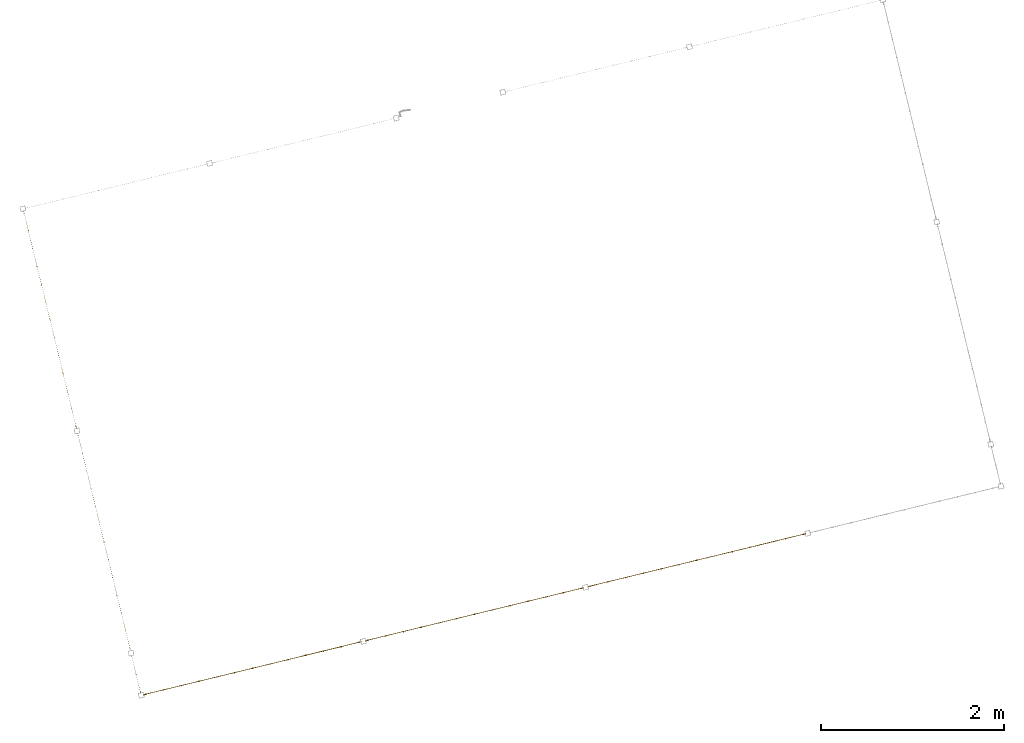
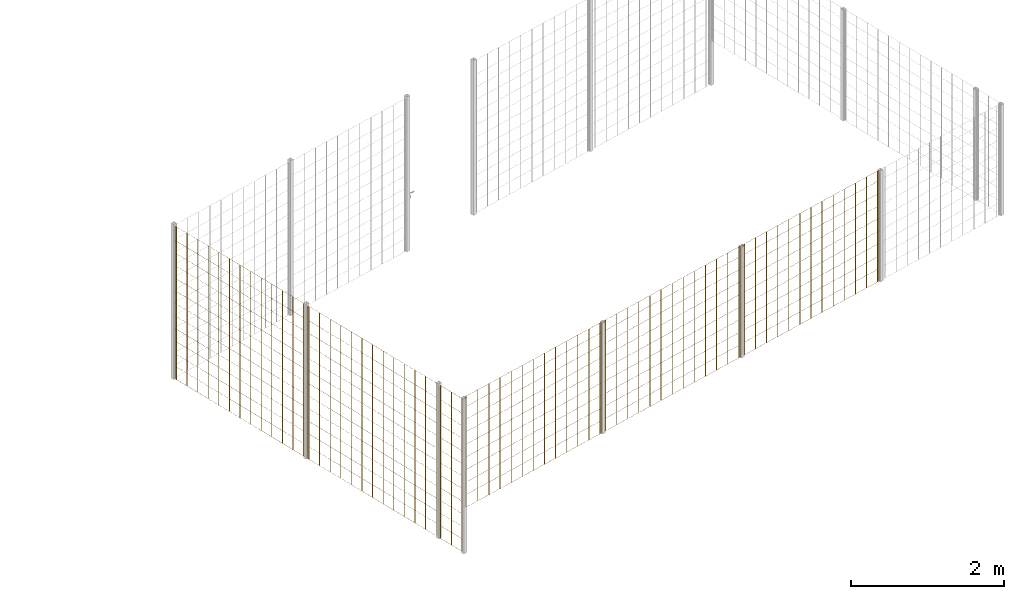
# One storey, part 7 of 10: 6 railings.
"""IFC2X3 building model written with IfcOpenShell, lengths in millimetres."""

from ifc_helpers import new_model, entity, si_unit, converted_unit, derived_unit, direction, frame, origin, origin_2d_with_axis, place, context, subcontext, project, spatial, rectangle, circle, extrude, material, material_list, element, save


model = new_model("IFC2X3")

# Units and contexts
model_context = context("Model", 3, precision=0.01, world=origin(), true_north=direction((6.12303176911189e-17, 1.0)))
body_context = subcontext(model_context, "Body", "Model", "MODEL_VIEW")
ifc_project = project(units=[si_unit("LENGTHUNIT", "METRE", prefix="MILLI"), si_unit("AREAUNIT", "SQUARE_METRE"), si_unit("VOLUMEUNIT", "CUBIC_METRE"), converted_unit("PLANEANGLEUNIT", "DEGREE", entity("IfcRatioMeasure", 0.0174532925199433), si_unit("PLANEANGLEUNIT", "RADIAN"), dimensions=[0, 0, 0, 0, 0, 0, 0]), si_unit("MASSUNIT", "GRAM", prefix="KILO"), derived_unit("MASSDENSITYUNIT", [(si_unit("MASSUNIT", "GRAM", prefix="KILO"), 1), (si_unit("LENGTHUNIT", "METRE"), -3)]), derived_unit("MOMENTOFINERTIAUNIT", [(si_unit("LENGTHUNIT", "METRE"), 4)]), si_unit("TIMEUNIT", "SECOND"), si_unit("FREQUENCYUNIT", "HERTZ"), si_unit("THERMODYNAMICTEMPERATUREUNIT", "DEGREE_CELSIUS"), derived_unit("THERMALTRANSMITTANCEUNIT", [(si_unit("MASSUNIT", "GRAM", prefix="KILO"), 1), (si_unit("THERMODYNAMICTEMPERATUREUNIT", "KELVIN"), -1), (si_unit("TIMEUNIT", "SECOND"), -3)]), derived_unit("VOLUMETRICFLOWRATEUNIT", [(si_unit("LENGTHUNIT", "METRE"), 3), (si_unit("TIMEUNIT", "SECOND"), -1)]), derived_unit("MASSFLOWRATEUNIT", [(si_unit("MASSUNIT", "GRAM", prefix="KILO"), 1), (si_unit("TIMEUNIT", "SECOND"), -1)]), derived_unit("ROTATIONALFREQUENCYUNIT", [(si_unit("TIMEUNIT", "SECOND"), -1)]), si_unit("ELECTRICCURRENTUNIT", "AMPERE"), si_unit("ELECTRICVOLTAGEUNIT", "VOLT"), si_unit("POWERUNIT", "WATT"), si_unit("FORCEUNIT", "NEWTON", prefix="KILO"), si_unit("ILLUMINANCEUNIT", "LUX"), si_unit("LUMINOUSFLUXUNIT", "LUMEN"), si_unit("LUMINOUSINTENSITYUNIT", "CANDELA"), derived_unit("USERDEFINED", [(si_unit("MASSUNIT", "GRAM", prefix="KILO"), -1), (si_unit("LENGTHUNIT", "METRE"), -2), (si_unit("TIMEUNIT", "SECOND"), 3), (si_unit("LUMINOUSFLUXUNIT", "LUMEN"), 1)]), derived_unit("LINEARVELOCITYUNIT", [(si_unit("LENGTHUNIT", "METRE"), 1), (si_unit("TIMEUNIT", "SECOND"), -1)]), si_unit("PRESSUREUNIT", "PASCAL"), derived_unit("USERDEFINED", [(si_unit("LENGTHUNIT", "METRE"), -2), (si_unit("MASSUNIT", "GRAM", prefix="KILO"), 1), (si_unit("TIMEUNIT", "SECOND"), -2)]), derived_unit("LINEARFORCEUNIT", [(si_unit("MASSUNIT", "GRAM", prefix="KILO"), 1), (si_unit("LENGTHUNIT", "METRE"), 1), (si_unit("TIMEUNIT", "SECOND"), -2), (si_unit("LENGTHUNIT", "METRE"), -1)]), derived_unit("PLANARFORCEUNIT", [(si_unit("MASSUNIT", "GRAM", prefix="KILO"), 1), (si_unit("LENGTHUNIT", "METRE"), 1), (si_unit("TIMEUNIT", "SECOND"), -2), (si_unit("LENGTHUNIT", "METRE"), -2)])], contexts=[model_context])

# Site, building, storey
site_placement = place(None, frame((19171.75, -72498.58, 0.0), z_axis=(0.0, 0.0, 1.0), x_axis=(0.971695960795463, 0.236234967296933, 0.0)))
site = spatial("IfcSite", under=ifc_project, at=site_placement, CompositionType="ELEMENT")
building_placement = place(site_placement, origin())
building = spatial("IfcBuilding", under=site, at=building_placement, CompositionType="ELEMENT")
storey_placement = place(building_placement, origin())
storey = spatial("IfcBuildingStorey", under=building, at=storey_placement, Name="01", CompositionType="ELEMENT", Elevation=0.0)

# Railings
ifc_material = material()
ifc_material_list_1 = material_list([ifc_material, ifc_material, ifc_material, ifc_material, ifc_material, ifc_material, ifc_material, ifc_material, ifc_material, ifc_material, ifc_material, ifc_material, ifc_material, ifc_material, ifc_material, ifc_material, ifc_material, ifc_material, ifc_material, ifc_material, ifc_material, ifc_material, ifc_material, ifc_material, ifc_material, ifc_material, ifc_material, ifc_material])
railing_1_placement = place(storey_placement, frame((193.41, 620.91, 0.0)))
element("IfcRailing", 1, at=railing_1_placement, inside=storey, material=ifc_material_list_1, PredefinedType="NOTDEFINED", context=body_context, shape_type="SweptSolid", body=[
    extrude(circle(Radius=5.0, at=origin_2d_with_axis()), frame((6.59, 2429.09, 2.0), z_axis=(0.0, 0.0, 1.0), x_axis=(-1.0, 0.0, 0.0)), (0.0, 0.0, 1.0), 2428.0),
    extrude(circle(Radius=5.0, at=origin_2d_with_axis()), frame((6.59, 2229.09, 2.0), z_axis=(0.0, 0.0, 1.0), x_axis=(-1.0, 0.0, 0.0)), (0.0, 0.0, 1.0), 2428.0),
    extrude(circle(Radius=5.0, at=origin_2d_with_axis()), frame((6.59, 2029.09, 2.0), z_axis=(0.0, 0.0, 1.0), x_axis=(-1.0, 0.0, 0.0)), (0.0, 0.0, 1.0), 2428.0),
    extrude(circle(Radius=5.0, at=origin_2d_with_axis()), frame((6.59, 1829.09, 2.0), z_axis=(0.0, 0.0, 1.0), x_axis=(-1.0, 0.0, 0.0)), (0.0, 0.0, 1.0), 2428.0),
    extrude(circle(Radius=5.0, at=origin_2d_with_axis()), frame((6.59, 1629.09, 2.0), z_axis=(0.0, 0.0, 1.0), x_axis=(-1.0, 0.0, 0.0)), (0.0, 0.0, 1.0), 2428.0),
    extrude(circle(Radius=5.0, at=origin_2d_with_axis()), frame((6.59, 1429.09, 2.0), z_axis=(0.0, 0.0, 1.0), x_axis=(-1.0, 0.0, 0.0)), (0.0, 0.0, 1.0), 2428.0),
    extrude(circle(Radius=5.0, at=origin_2d_with_axis()), frame((6.59, 1229.09, 2.0), z_axis=(0.0, 0.0, 1.0), x_axis=(-1.0, 0.0, 0.0)), (0.0, 0.0, 1.0), 2428.0),
    extrude(circle(Radius=5.0, at=origin_2d_with_axis()), frame((6.59, 1029.09, 2.0), z_axis=(0.0, 0.0, 1.0), x_axis=(-1.0, 0.0, 0.0)), (0.0, 0.0, 1.0), 2428.0),
    extrude(circle(Radius=5.0, at=origin_2d_with_axis()), frame((6.59, 829.09, 2.0), z_axis=(0.0, 0.0, 1.0), x_axis=(-1.0, 0.0, 0.0)), (0.0, 0.0, 1.0), 2428.0),
    extrude(circle(Radius=5.0, at=origin_2d_with_axis()), frame((6.59, 629.09, 2.0), z_axis=(0.0, 0.0, 1.0), x_axis=(-1.0, 0.0, 0.0)), (0.0, 0.0, 1.0), 2428.0),
    extrude(circle(Radius=5.0, at=origin_2d_with_axis()), frame((6.59, 429.09, 2.0), z_axis=(0.0, 0.0, 1.0), x_axis=(-1.0, 0.0, 0.0)), (0.0, 0.0, 1.0), 2428.0),
    extrude(circle(Radius=5.0, at=origin_2d_with_axis()), frame((6.59, 229.09, 2.0), z_axis=(0.0, 0.0, 1.0), x_axis=(-1.0, 0.0, 0.0)), (0.0, 0.0, 1.0), 2428.0),
    extrude(circle(Radius=5.0, at=origin_2d_with_axis()), frame((6.59, 29.09, 2.0), z_axis=(0.0, 0.0, 1.0), x_axis=(-1.0, 0.0, 0.0)), (0.0, 0.0, 1.0), 2428.0),
    extrude(circle(Radius=5.0, at=origin_2d_with_axis()), frame((6.59, 2451.59, 2.0), z_axis=(0.0, 0.0, 1.0), x_axis=(-1.0, 0.0, 0.0)), (0.0, 0.0, 1.0), 2428.0),
    extrude(circle(Radius=5.0, at=origin_2d_with_axis()), frame((6.59, 6.59, 2.0), z_axis=(0.0, 0.0, 1.0), x_axis=(-1.0, 0.0, 0.0)), (0.0, 0.0, 1.0), 2428.0),
    extrude(rectangle(XDim=2445.0, YDim=1.99999999999988, at=origin_2d_with_axis()), frame((7.59, 1229.09, 0.0), z_axis=(0.0, 0.0, 1.0), x_axis=(0.0, 1.0, 0.0)), (0.0, 0.0, 1.0), 2.00000000000043),
    extrude(rectangle(XDim=2445.0, YDim=1.99999999999988, at=origin_2d_with_axis()), frame((7.59, 1229.09, 200.0), z_axis=(0.0, 0.0, 1.0), x_axis=(0.0, 1.0, 0.0)), (0.0, 0.0, 1.0), 2.00000000000043),
    extrude(rectangle(XDim=2445.0, YDim=1.99999999999988, at=origin_2d_with_axis()), frame((7.59, 1229.09, 400.0), z_axis=(0.0, 0.0, 1.0), x_axis=(0.0, 1.0, 0.0)), (0.0, 0.0, 1.0), 2.00000000000043),
    extrude(rectangle(XDim=2445.0, YDim=1.99999999999988, at=origin_2d_with_axis()), frame((7.59, 1229.09, 600.0), z_axis=(0.0, 0.0, 1.0), x_axis=(0.0, 1.0, 0.0)), (0.0, 0.0, 1.0), 2.00000000000043),
    extrude(rectangle(XDim=2445.0, YDim=1.99999999999988, at=origin_2d_with_axis()), frame((7.59, 1229.09, 800.0), z_axis=(0.0, 0.0, 1.0), x_axis=(0.0, 1.0, 0.0)), (0.0, 0.0, 1.0), 2.00000000000036),
    extrude(rectangle(XDim=2445.0, YDim=1.99999999999988, at=origin_2d_with_axis()), frame((7.59, 1229.09, 1000.0), z_axis=(0.0, 0.0, 1.0), x_axis=(0.0, 1.0, 0.0)), (0.0, 0.0, 1.0), 2.00000000000036),
    extrude(rectangle(XDim=2445.0, YDim=1.99999999999988, at=origin_2d_with_axis()), frame((7.59, 1229.09, 1200.0), z_axis=(0.0, 0.0, 1.0), x_axis=(0.0, 1.0, 0.0)), (0.0, 0.0, 1.0), 2.00000000000036),
    extrude(rectangle(XDim=2445.0, YDim=1.99999999999988, at=origin_2d_with_axis()), frame((7.59, 1229.09, 1400.0), z_axis=(0.0, 0.0, 1.0), x_axis=(0.0, 1.0, 0.0)), (0.0, 0.0, 1.0), 2.00000000000036),
    extrude(rectangle(XDim=2445.0, YDim=1.99999999999988, at=origin_2d_with_axis()), frame((7.59, 1229.09, 1600.0), z_axis=(0.0, 0.0, 1.0), x_axis=(0.0, 1.0, 0.0)), (0.0, 0.0, 1.0), 2.00000000000036),
    extrude(rectangle(XDim=2445.0, YDim=1.99999999999988, at=origin_2d_with_axis()), frame((7.59, 1229.09, 1800.0), z_axis=(0.0, 0.0, 1.0), x_axis=(0.0, 1.0, 0.0)), (0.0, 0.0, 1.0), 2.00000000000036),
    extrude(rectangle(XDim=2445.0, YDim=1.99999999999988, at=origin_2d_with_axis()), frame((7.59, 1229.09, 2000.0), z_axis=(0.0, 0.0, 1.0), x_axis=(0.0, 1.0, 0.0)), (0.0, 0.0, 1.0), 2.00000000000036),
    extrude(rectangle(XDim=2445.0, YDim=1.99999999999988, at=origin_2d_with_axis()), frame((7.59, 1229.09, 2200.0), z_axis=(0.0, 0.0, 1.0), x_axis=(0.0, 1.0, 0.0)), (0.0, 0.0, 1.0), 2.00000000000036),
    extrude(rectangle(XDim=2445.0, YDim=1.99999999999988, at=origin_2d_with_axis()), frame((7.59, 1229.09, 2430.0), z_axis=(0.0, 0.0, 1.0), x_axis=(0.0, 1.0, 0.0)), (0.0, 0.0, 1.0), 2.00000000000036),
])
railing_2_placement = place(storey_placement, frame((193.41, 3120.91, 0.0)))
element("IfcRailing", 2, at=railing_2_placement, inside=storey, material=ifc_material_list_1, PredefinedType="NOTDEFINED", context=body_context, shape_type="SweptSolid", body=[
    extrude(circle(Radius=5.0, at=origin_2d_with_axis()), frame((6.59, 2429.79, 2.0), z_axis=(0.0, 0.0, 1.0), x_axis=(-1.0, 0.0, 0.0)), (0.0, 0.0, 1.0), 2428.0),
    extrude(circle(Radius=5.0, at=origin_2d_with_axis()), frame((6.59, 2229.79, 2.0), z_axis=(0.0, 0.0, 1.0), x_axis=(-1.0, 0.0, 0.0)), (0.0, 0.0, 1.0), 2428.0),
    extrude(circle(Radius=5.0, at=origin_2d_with_axis()), frame((6.59, 2029.79, 2.0), z_axis=(0.0, 0.0, 1.0), x_axis=(-1.0, 0.0, 0.0)), (0.0, 0.0, 1.0), 2428.0),
    extrude(circle(Radius=5.0, at=origin_2d_with_axis()), frame((6.59, 1829.79, 2.0), z_axis=(0.0, 0.0, 1.0), x_axis=(-1.0, 0.0, 0.0)), (0.0, 0.0, 1.0), 2428.0),
    extrude(circle(Radius=5.0, at=origin_2d_with_axis()), frame((6.59, 1629.79, 2.0), z_axis=(0.0, 0.0, 1.0), x_axis=(-1.0, 0.0, 0.0)), (0.0, 0.0, 1.0), 2428.0),
    extrude(circle(Radius=5.0, at=origin_2d_with_axis()), frame((6.59, 1429.79, 2.0), z_axis=(0.0, 0.0, 1.0), x_axis=(-1.0, 0.0, 0.0)), (0.0, 0.0, 1.0), 2428.0),
    extrude(circle(Radius=5.0, at=origin_2d_with_axis()), frame((6.59, 1229.79, 2.0), z_axis=(0.0, 0.0, 1.0), x_axis=(-1.0, 0.0, 0.0)), (0.0, 0.0, 1.0), 2428.0),
    extrude(circle(Radius=5.0, at=origin_2d_with_axis()), frame((6.59, 1029.79, 2.0), z_axis=(0.0, 0.0, 1.0), x_axis=(-1.0, 0.0, 0.0)), (0.0, 0.0, 1.0), 2428.0),
    extrude(circle(Radius=5.0, at=origin_2d_with_axis()), frame((6.59, 829.79, 2.0), z_axis=(0.0, 0.0, 1.0), x_axis=(-1.0, 0.0, 0.0)), (0.0, 0.0, 1.0), 2428.0),
    extrude(circle(Radius=5.0, at=origin_2d_with_axis()), frame((6.59, 629.79, 2.0), z_axis=(0.0, 0.0, 1.0), x_axis=(-1.0, 0.0, 0.0)), (0.0, 0.0, 1.0), 2428.0),
    extrude(circle(Radius=5.0, at=origin_2d_with_axis()), frame((6.59, 429.79, 2.0), z_axis=(0.0, 0.0, 1.0), x_axis=(-1.0, 0.0, 0.0)), (0.0, 0.0, 1.0), 2428.0),
    extrude(circle(Radius=5.0, at=origin_2d_with_axis()), frame((6.59, 229.79, 2.0), z_axis=(0.0, 0.0, 1.0), x_axis=(-1.0, 0.0, 0.0)), (0.0, 0.0, 1.0), 2428.0),
    extrude(circle(Radius=5.0, at=origin_2d_with_axis()), frame((6.59, 29.79, 2.0), z_axis=(0.0, 0.0, 1.0), x_axis=(-1.0, 0.0, 0.0)), (0.0, 0.0, 1.0), 2428.0),
    extrude(circle(Radius=5.0, at=origin_2d_with_axis()), frame((6.59, 2452.99, 2.0), z_axis=(0.0, 0.0, 1.0), x_axis=(-1.0, 0.0, 0.0)), (0.0, 0.0, 1.0), 2428.0),
    extrude(circle(Radius=5.0, at=origin_2d_with_axis()), frame((6.59, 6.59, 2.0), z_axis=(0.0, 0.0, 1.0), x_axis=(-1.0, 0.0, 0.0)), (0.0, 0.0, 1.0), 2428.0),
    extrude(rectangle(XDim=2446.40000000003, YDim=1.99999999999988, at=origin_2d_with_axis()), frame((7.59, 1229.79, 0.0), z_axis=(0.0, 0.0, 1.0), x_axis=(0.0, 1.0, 0.0)), (0.0, 0.0, 1.0), 2.00000000000043),
    extrude(rectangle(XDim=2446.40000000003, YDim=1.99999999999988, at=origin_2d_with_axis()), frame((7.59, 1229.79, 200.0), z_axis=(0.0, 0.0, 1.0), x_axis=(0.0, 1.0, 0.0)), (0.0, 0.0, 1.0), 2.00000000000043),
    extrude(rectangle(XDim=2446.40000000003, YDim=1.99999999999988, at=origin_2d_with_axis()), frame((7.59, 1229.79, 400.0), z_axis=(0.0, 0.0, 1.0), x_axis=(0.0, 1.0, 0.0)), (0.0, 0.0, 1.0), 2.00000000000043),
    extrude(rectangle(XDim=2446.40000000003, YDim=1.99999999999988, at=origin_2d_with_axis()), frame((7.59, 1229.79, 600.0), z_axis=(0.0, 0.0, 1.0), x_axis=(0.0, 1.0, 0.0)), (0.0, 0.0, 1.0), 2.00000000000043),
    extrude(rectangle(XDim=2446.40000000003, YDim=1.99999999999988, at=origin_2d_with_axis()), frame((7.59, 1229.79, 800.0), z_axis=(0.0, 0.0, 1.0), x_axis=(0.0, 1.0, 0.0)), (0.0, 0.0, 1.0), 2.00000000000036),
    extrude(rectangle(XDim=2446.40000000003, YDim=1.99999999999988, at=origin_2d_with_axis()), frame((7.59, 1229.79, 1000.0), z_axis=(0.0, 0.0, 1.0), x_axis=(0.0, 1.0, 0.0)), (0.0, 0.0, 1.0), 2.00000000000036),
    extrude(rectangle(XDim=2446.40000000003, YDim=1.99999999999988, at=origin_2d_with_axis()), frame((7.59, 1229.79, 1200.0), z_axis=(0.0, 0.0, 1.0), x_axis=(0.0, 1.0, 0.0)), (0.0, 0.0, 1.0), 2.00000000000036),
    extrude(rectangle(XDim=2446.40000000003, YDim=1.99999999999988, at=origin_2d_with_axis()), frame((7.59, 1229.79, 1400.0), z_axis=(0.0, 0.0, 1.0), x_axis=(0.0, 1.0, 0.0)), (0.0, 0.0, 1.0), 2.00000000000036),
    extrude(rectangle(XDim=2446.40000000003, YDim=1.99999999999988, at=origin_2d_with_axis()), frame((7.59, 1229.79, 1600.0), z_axis=(0.0, 0.0, 1.0), x_axis=(0.0, 1.0, 0.0)), (0.0, 0.0, 1.0), 2.00000000000036),
    extrude(rectangle(XDim=2446.40000000003, YDim=1.99999999999988, at=origin_2d_with_axis()), frame((7.59, 1229.79, 1800.0), z_axis=(0.0, 0.0, 1.0), x_axis=(0.0, 1.0, 0.0)), (0.0, 0.0, 1.0), 2.00000000000036),
    extrude(rectangle(XDim=2446.40000000003, YDim=1.99999999999988, at=origin_2d_with_axis()), frame((7.59, 1229.79, 2000.0), z_axis=(0.0, 0.0, 1.0), x_axis=(0.0, 1.0, 0.0)), (0.0, 0.0, 1.0), 2.00000000000036),
    extrude(rectangle(XDim=2446.40000000003, YDim=1.99999999999988, at=origin_2d_with_axis()), frame((7.59, 1229.79, 2200.0), z_axis=(0.0, 0.0, 1.0), x_axis=(0.0, 1.0, 0.0)), (0.0, 0.0, 1.0), 2.00000000000036),
    extrude(rectangle(XDim=2446.40000000003, YDim=1.99999999999988, at=origin_2d_with_axis()), frame((7.59, 1229.79, 2430.0), z_axis=(0.0, 0.0, 1.0), x_axis=(0.0, 1.0, 0.0)), (0.0, 0.0, 1.0), 2.00000000000036),
])
ifc_material_list_2 = material_list([ifc_material, ifc_material, ifc_material, ifc_material, ifc_material, ifc_material, ifc_material, ifc_material, ifc_material, ifc_material, ifc_material, ifc_material, ifc_material, ifc_material, ifc_material, ifc_material, ifc_material, ifc_material, ifc_material, ifc_material, ifc_material, ifc_material, ifc_material, ifc_material, ifc_material])
railing_3_placement = place(storey_placement, frame((5220.91, 118.41, 700.0)))
element("IfcRailing", 3, at=railing_3_placement, inside=storey, material=ifc_material_list_2, Name=": 2", ObjectType=": 2", PredefinedType="NOTDEFINED", context=body_context, shape_type="SweptSolid", body=[
    extrude(circle(Radius=5.0, at=origin_2d_with_axis()), frame((29.79, 6.59, 2.0), z_axis=(0.0, 0.0, 1.0), x_axis=(0.0, -1.0, 0.0)), (0.0, 0.0, 1.0), 1763.0),
    extrude(circle(Radius=5.0, at=origin_2d_with_axis()), frame((229.79, 6.59, 2.0), z_axis=(0.0, 0.0, 1.0), x_axis=(0.0, -1.0, 0.0)), (0.0, 0.0, 1.0), 1763.0),
    extrude(circle(Radius=5.0, at=origin_2d_with_axis()), frame((429.79, 6.59, 2.0), z_axis=(0.0, 0.0, 1.0), x_axis=(0.0, -1.0, 0.0)), (0.0, 0.0, 1.0), 1763.0),
    extrude(circle(Radius=5.0, at=origin_2d_with_axis()), frame((629.79, 6.59, 2.0), z_axis=(0.0, 0.0, 1.0), x_axis=(0.0, -1.0, 0.0)), (0.0, 0.0, 1.0), 1763.0),
    extrude(circle(Radius=5.0, at=origin_2d_with_axis()), frame((829.79, 6.59, 2.0), z_axis=(0.0, 0.0, 1.0), x_axis=(0.0, -1.0, 0.0)), (0.0, 0.0, 1.0), 1763.0),
    extrude(circle(Radius=5.0, at=origin_2d_with_axis()), frame((1029.79, 6.59, 2.0), z_axis=(0.0, 0.0, 1.0), x_axis=(0.0, -1.0, 0.0)), (0.0, 0.0, 1.0), 1763.0),
    extrude(circle(Radius=5.0, at=origin_2d_with_axis()), frame((1229.79, 6.59, 2.0), z_axis=(0.0, 0.0, 1.0), x_axis=(0.0, -1.0, 0.0)), (0.0, 0.0, 1.0), 1763.0),
    extrude(circle(Radius=5.0, at=origin_2d_with_axis()), frame((1429.79, 6.59, 2.0), z_axis=(0.0, 0.0, 1.0), x_axis=(0.0, -1.0, 0.0)), (0.0, 0.0, 1.0), 1763.0),
    extrude(circle(Radius=5.0, at=origin_2d_with_axis()), frame((1629.79, 6.59, 2.0), z_axis=(0.0, 0.0, 1.0), x_axis=(0.0, -1.0, 0.0)), (0.0, 0.0, 1.0), 1763.0),
    extrude(circle(Radius=5.0, at=origin_2d_with_axis()), frame((1829.79, 6.59, 2.0), z_axis=(0.0, 0.0, 1.0), x_axis=(0.0, -1.0, 0.0)), (0.0, 0.0, 1.0), 1763.0),
    extrude(circle(Radius=5.0, at=origin_2d_with_axis()), frame((2029.79, 6.59, 2.0), z_axis=(0.0, 0.0, 1.0), x_axis=(0.0, -1.0, 0.0)), (0.0, 0.0, 1.0), 1763.0),
    extrude(circle(Radius=5.0, at=origin_2d_with_axis()), frame((2229.79, 6.59, 2.0), z_axis=(0.0, 0.0, 1.0), x_axis=(0.0, -1.0, 0.0)), (0.0, 0.0, 1.0), 1763.0),
    extrude(circle(Radius=5.0, at=origin_2d_with_axis()), frame((2429.79, 6.59, 2.0), z_axis=(0.0, 0.0, 1.0), x_axis=(0.0, -1.0, 0.0)), (0.0, 0.0, 1.0), 1763.0),
    extrude(circle(Radius=5.0, at=origin_2d_with_axis()), frame((6.59, 6.59, 2.0), z_axis=(0.0, 0.0, 1.0), x_axis=(0.0, -1.0, 0.0)), (0.0, 0.0, 1.0), 1763.0),
    extrude(circle(Radius=5.0, at=origin_2d_with_axis()), frame((2452.99, 6.59, 2.0), z_axis=(0.0, 0.0, 1.0), x_axis=(0.0, -1.0, 0.0)), (0.0, 0.0, 1.0), 1763.0),
    extrude(rectangle(XDim=2446.4, YDim=1.99999999999988, at=origin_2d_with_axis()), frame((1229.79, 7.59, 0.0), z_axis=(0.0, 0.0, 1.0), x_axis=(-1.0, 0.0, 0.0)), (0.0, 0.0, 1.0), 2.00000000000036),
    extrude(rectangle(XDim=2446.4, YDim=1.99999999999988, at=origin_2d_with_axis()), frame((1229.79, 7.59, 200.0), z_axis=(0.0, 0.0, 1.0), x_axis=(-1.0, 0.0, 0.0)), (0.0, 0.0, 1.0), 2.00000000000036),
    extrude(rectangle(XDim=2446.4, YDim=1.99999999999988, at=origin_2d_with_axis()), frame((1229.79, 7.59, 400.0), z_axis=(0.0, 0.0, 1.0), x_axis=(-1.0, 0.0, 0.0)), (0.0, 0.0, 1.0), 2.00000000000036),
    extrude(rectangle(XDim=2446.4, YDim=1.99999999999988, at=origin_2d_with_axis()), frame((1229.79, 7.59, 600.0), z_axis=(0.0, 0.0, 1.0), x_axis=(-1.0, 0.0, 0.0)), (0.0, 0.0, 1.0), 2.00000000000036),
    extrude(rectangle(XDim=2446.4, YDim=1.99999999999988, at=origin_2d_with_axis()), frame((1229.79, 7.59, 800.0), z_axis=(0.0, 0.0, 1.0), x_axis=(-1.0, 0.0, 0.0)), (0.0, 0.0, 1.0), 2.00000000000036),
    extrude(rectangle(XDim=2446.4, YDim=1.99999999999988, at=origin_2d_with_axis()), frame((1229.79, 7.59, 1000.0), z_axis=(0.0, 0.0, 1.0), x_axis=(-1.0, 0.0, 0.0)), (0.0, 0.0, 1.0), 2.00000000000036),
    extrude(rectangle(XDim=2446.4, YDim=1.99999999999988, at=origin_2d_with_axis()), frame((1229.79, 7.59, 1200.0), z_axis=(0.0, 0.0, 1.0), x_axis=(-1.0, 0.0, 0.0)), (0.0, 0.0, 1.0), 2.00000000000036),
    extrude(rectangle(XDim=2446.4, YDim=1.99999999999988, at=origin_2d_with_axis()), frame((1229.79, 7.59, 1400.0), z_axis=(0.0, 0.0, 1.0), x_axis=(-1.0, 0.0, 0.0)), (0.0, 0.0, 1.0), 2.00000000000036),
    extrude(rectangle(XDim=2446.4, YDim=1.99999999999988, at=origin_2d_with_axis()), frame((1229.79, 7.59, 1600.0), z_axis=(0.0, 0.0, 1.0), x_axis=(-1.0, 0.0, 0.0)), (0.0, 0.0, 1.0), 2.00000000000036),
    extrude(rectangle(XDim=2446.4, YDim=1.99999999999988, at=origin_2d_with_axis()), frame((1229.79, 7.59, 1765.0), z_axis=(0.0, 0.0, 1.0), x_axis=(-1.0, 0.0, 0.0)), (0.0, 0.0, 1.0), 2.00000000000063),
])
railing_4_placement = place(storey_placement, frame((2720.91, 118.41, 700.0)))
element("IfcRailing", 4, at=railing_4_placement, inside=storey, material=ifc_material_list_2, Name=": 2", ObjectType=": 2", PredefinedType="NOTDEFINED", context=body_context, shape_type="SweptSolid", body=[
    extrude(circle(Radius=5.0, at=origin_2d_with_axis()), frame((29.09, 6.59, 2.0), z_axis=(0.0, 0.0, 1.0), x_axis=(0.0, -1.0, 0.0)), (0.0, 0.0, 1.0), 1763.0),
    extrude(circle(Radius=5.0, at=origin_2d_with_axis()), frame((229.09, 6.59, 2.0), z_axis=(0.0, 0.0, 1.0), x_axis=(0.0, -1.0, 0.0)), (0.0, 0.0, 1.0), 1763.0),
    extrude(circle(Radius=5.0, at=origin_2d_with_axis()), frame((429.09, 6.59, 2.0), z_axis=(0.0, 0.0, 1.0), x_axis=(0.0, -1.0, 0.0)), (0.0, 0.0, 1.0), 1763.0),
    extrude(circle(Radius=5.0, at=origin_2d_with_axis()), frame((629.09, 6.59, 2.0), z_axis=(0.0, 0.0, 1.0), x_axis=(0.0, -1.0, 0.0)), (0.0, 0.0, 1.0), 1763.0),
    extrude(circle(Radius=5.0, at=origin_2d_with_axis()), frame((829.09, 6.59, 2.0), z_axis=(0.0, 0.0, 1.0), x_axis=(0.0, -1.0, 0.0)), (0.0, 0.0, 1.0), 1763.0),
    extrude(circle(Radius=5.0, at=origin_2d_with_axis()), frame((1029.09, 6.59, 2.0), z_axis=(0.0, 0.0, 1.0), x_axis=(0.0, -1.0, 0.0)), (0.0, 0.0, 1.0), 1763.0),
    extrude(circle(Radius=5.0, at=origin_2d_with_axis()), frame((1229.09, 6.59, 2.0), z_axis=(0.0, 0.0, 1.0), x_axis=(0.0, -1.0, 0.0)), (0.0, 0.0, 1.0), 1763.0),
    extrude(circle(Radius=5.0, at=origin_2d_with_axis()), frame((1429.09, 6.59, 2.0), z_axis=(0.0, 0.0, 1.0), x_axis=(0.0, -1.0, 0.0)), (0.0, 0.0, 1.0), 1763.0),
    extrude(circle(Radius=5.0, at=origin_2d_with_axis()), frame((1629.09, 6.59, 2.0), z_axis=(0.0, 0.0, 1.0), x_axis=(0.0, -1.0, 0.0)), (0.0, 0.0, 1.0), 1763.0),
    extrude(circle(Radius=5.0, at=origin_2d_with_axis()), frame((1829.09, 6.59, 2.0), z_axis=(0.0, 0.0, 1.0), x_axis=(0.0, -1.0, 0.0)), (0.0, 0.0, 1.0), 1763.0),
    extrude(circle(Radius=5.0, at=origin_2d_with_axis()), frame((2029.09, 6.59, 2.0), z_axis=(0.0, 0.0, 1.0), x_axis=(0.0, -1.0, 0.0)), (0.0, 0.0, 1.0), 1763.0),
    extrude(circle(Radius=5.0, at=origin_2d_with_axis()), frame((2229.09, 6.59, 2.0), z_axis=(0.0, 0.0, 1.0), x_axis=(0.0, -1.0, 0.0)), (0.0, 0.0, 1.0), 1763.0),
    extrude(circle(Radius=5.0, at=origin_2d_with_axis()), frame((2429.09, 6.59, 2.0), z_axis=(0.0, 0.0, 1.0), x_axis=(0.0, -1.0, 0.0)), (0.0, 0.0, 1.0), 1763.0),
    extrude(circle(Radius=5.0, at=origin_2d_with_axis()), frame((6.59, 6.59, 2.0), z_axis=(0.0, 0.0, 1.0), x_axis=(0.0, -1.0, 0.0)), (0.0, 0.0, 1.0), 1763.0),
    extrude(circle(Radius=5.0, at=origin_2d_with_axis()), frame((2451.59, 6.59, 2.0), z_axis=(0.0, 0.0, 1.0), x_axis=(0.0, -1.0, 0.0)), (0.0, 0.0, 1.0), 1763.0),
    extrude(rectangle(XDim=2445.0, YDim=1.9999999999999, at=origin_2d_with_axis()), frame((1229.09, 7.59, 0.0), z_axis=(0.0, 0.0, 1.0), x_axis=(-1.0, 0.0, 0.0)), (0.0, 0.0, 1.0), 2.00000000000036),
    extrude(rectangle(XDim=2445.0, YDim=1.9999999999999, at=origin_2d_with_axis()), frame((1229.09, 7.59, 200.0), z_axis=(0.0, 0.0, 1.0), x_axis=(-1.0, 0.0, 0.0)), (0.0, 0.0, 1.0), 2.00000000000036),
    extrude(rectangle(XDim=2445.0, YDim=1.9999999999999, at=origin_2d_with_axis()), frame((1229.09, 7.59, 400.0), z_axis=(0.0, 0.0, 1.0), x_axis=(-1.0, 0.0, 0.0)), (0.0, 0.0, 1.0), 2.00000000000036),
    extrude(rectangle(XDim=2445.0, YDim=1.9999999999999, at=origin_2d_with_axis()), frame((1229.09, 7.59, 600.0), z_axis=(0.0, 0.0, 1.0), x_axis=(-1.0, 0.0, 0.0)), (0.0, 0.0, 1.0), 2.00000000000036),
    extrude(rectangle(XDim=2445.0, YDim=1.9999999999999, at=origin_2d_with_axis()), frame((1229.09, 7.59, 800.0), z_axis=(0.0, 0.0, 1.0), x_axis=(-1.0, 0.0, 0.0)), (0.0, 0.0, 1.0), 2.00000000000036),
    extrude(rectangle(XDim=2445.0, YDim=1.9999999999999, at=origin_2d_with_axis()), frame((1229.09, 7.59, 1000.0), z_axis=(0.0, 0.0, 1.0), x_axis=(-1.0, 0.0, 0.0)), (0.0, 0.0, 1.0), 2.00000000000036),
    extrude(rectangle(XDim=2445.0, YDim=1.9999999999999, at=origin_2d_with_axis()), frame((1229.09, 7.59, 1200.0), z_axis=(0.0, 0.0, 1.0), x_axis=(-1.0, 0.0, 0.0)), (0.0, 0.0, 1.0), 2.00000000000036),
    extrude(rectangle(XDim=2445.0, YDim=1.9999999999999, at=origin_2d_with_axis()), frame((1229.09, 7.59, 1400.0), z_axis=(0.0, 0.0, 1.0), x_axis=(-1.0, 0.0, 0.0)), (0.0, 0.0, 1.0), 2.00000000000036),
    extrude(rectangle(XDim=2445.0, YDim=1.9999999999999, at=origin_2d_with_axis()), frame((1229.09, 7.59, 1600.0), z_axis=(0.0, 0.0, 1.0), x_axis=(-1.0, 0.0, 0.0)), (0.0, 0.0, 1.0), 2.00000000000036),
    extrude(rectangle(XDim=2445.0, YDim=1.9999999999999, at=origin_2d_with_axis()), frame((1229.09, 7.59, 1765.0), z_axis=(0.0, 0.0, 1.0), x_axis=(-1.0, 0.0, 0.0)), (0.0, 0.0, 1.0), 2.00000000000063),
])
railing_5_placement = place(storey_placement, frame((220.91, 118.41, 700.0)))
element("IfcRailing", 5, at=railing_5_placement, inside=storey, material=ifc_material_list_2, Name=": 2", ObjectType=": 2", PredefinedType="NOTDEFINED", context=body_context, shape_type="SweptSolid", body=[
    extrude(circle(Radius=5.0, at=origin_2d_with_axis()), frame((29.09, 6.59, 2.0), z_axis=(0.0, 0.0, 1.0), x_axis=(0.0, -1.0, 0.0)), (0.0, 0.0, 1.0), 1763.0),
    extrude(circle(Radius=5.0, at=origin_2d_with_axis()), frame((229.09, 6.59, 2.0), z_axis=(0.0, 0.0, 1.0), x_axis=(0.0, -1.0, 0.0)), (0.0, 0.0, 1.0), 1763.0),
    extrude(circle(Radius=5.0, at=origin_2d_with_axis()), frame((429.09, 6.59, 2.0), z_axis=(0.0, 0.0, 1.0), x_axis=(0.0, -1.0, 0.0)), (0.0, 0.0, 1.0), 1763.0),
    extrude(circle(Radius=5.0, at=origin_2d_with_axis()), frame((629.09, 6.59, 2.0), z_axis=(0.0, 0.0, 1.0), x_axis=(0.0, -1.0, 0.0)), (0.0, 0.0, 1.0), 1763.0),
    extrude(circle(Radius=5.0, at=origin_2d_with_axis()), frame((829.09, 6.59, 2.0), z_axis=(0.0, 0.0, 1.0), x_axis=(0.0, -1.0, 0.0)), (0.0, 0.0, 1.0), 1763.0),
    extrude(circle(Radius=5.0, at=origin_2d_with_axis()), frame((1029.09, 6.59, 2.0), z_axis=(0.0, 0.0, 1.0), x_axis=(0.0, -1.0, 0.0)), (0.0, 0.0, 1.0), 1763.0),
    extrude(circle(Radius=5.0, at=origin_2d_with_axis()), frame((1229.09, 6.59, 2.0), z_axis=(0.0, 0.0, 1.0), x_axis=(0.0, -1.0, 0.0)), (0.0, 0.0, 1.0), 1763.0),
    extrude(circle(Radius=5.0, at=origin_2d_with_axis()), frame((1429.09, 6.59, 2.0), z_axis=(0.0, 0.0, 1.0), x_axis=(0.0, -1.0, 0.0)), (0.0, 0.0, 1.0), 1763.0),
    extrude(circle(Radius=5.0, at=origin_2d_with_axis()), frame((1629.09, 6.59, 2.0), z_axis=(0.0, 0.0, 1.0), x_axis=(0.0, -1.0, 0.0)), (0.0, 0.0, 1.0), 1763.0),
    extrude(circle(Radius=5.0, at=origin_2d_with_axis()), frame((1829.09, 6.59, 2.0), z_axis=(0.0, 0.0, 1.0), x_axis=(0.0, -1.0, 0.0)), (0.0, 0.0, 1.0), 1763.0),
    extrude(circle(Radius=5.0, at=origin_2d_with_axis()), frame((2029.09, 6.59, 2.0), z_axis=(0.0, 0.0, 1.0), x_axis=(0.0, -1.0, 0.0)), (0.0, 0.0, 1.0), 1763.0),
    extrude(circle(Radius=5.0, at=origin_2d_with_axis()), frame((2229.09, 6.59, 2.0), z_axis=(0.0, 0.0, 1.0), x_axis=(0.0, -1.0, 0.0)), (0.0, 0.0, 1.0), 1763.0),
    extrude(circle(Radius=5.0, at=origin_2d_with_axis()), frame((2429.09, 6.59, 2.0), z_axis=(0.0, 0.0, 1.0), x_axis=(0.0, -1.0, 0.0)), (0.0, 0.0, 1.0), 1763.0),
    extrude(circle(Radius=5.0, at=origin_2d_with_axis()), frame((6.59, 6.59, 2.0), z_axis=(0.0, 0.0, 1.0), x_axis=(0.0, -1.0, 0.0)), (0.0, 0.0, 1.0), 1763.0),
    extrude(circle(Radius=5.0, at=origin_2d_with_axis()), frame((2451.59, 6.59, 2.0), z_axis=(0.0, 0.0, 1.0), x_axis=(0.0, -1.0, 0.0)), (0.0, 0.0, 1.0), 1763.0),
    extrude(rectangle(XDim=2445.0, YDim=1.9999999999999, at=origin_2d_with_axis()), frame((1229.09, 7.59, 0.0), z_axis=(0.0, 0.0, 1.0), x_axis=(-1.0, 0.0, 0.0)), (0.0, 0.0, 1.0), 2.00000000000036),
    extrude(rectangle(XDim=2445.0, YDim=1.9999999999999, at=origin_2d_with_axis()), frame((1229.09, 7.59, 200.0), z_axis=(0.0, 0.0, 1.0), x_axis=(-1.0, 0.0, 0.0)), (0.0, 0.0, 1.0), 2.00000000000036),
    extrude(rectangle(XDim=2445.0, YDim=1.9999999999999, at=origin_2d_with_axis()), frame((1229.09, 7.59, 400.0), z_axis=(0.0, 0.0, 1.0), x_axis=(-1.0, 0.0, 0.0)), (0.0, 0.0, 1.0), 2.00000000000036),
    extrude(rectangle(XDim=2445.0, YDim=1.9999999999999, at=origin_2d_with_axis()), frame((1229.09, 7.59, 600.0), z_axis=(0.0, 0.0, 1.0), x_axis=(-1.0, 0.0, 0.0)), (0.0, 0.0, 1.0), 2.00000000000036),
    extrude(rectangle(XDim=2445.0, YDim=1.9999999999999, at=origin_2d_with_axis()), frame((1229.09, 7.59, 800.0), z_axis=(0.0, 0.0, 1.0), x_axis=(-1.0, 0.0, 0.0)), (0.0, 0.0, 1.0), 2.00000000000036),
    extrude(rectangle(XDim=2445.0, YDim=1.9999999999999, at=origin_2d_with_axis()), frame((1229.09, 7.59, 1000.0), z_axis=(0.0, 0.0, 1.0), x_axis=(-1.0, 0.0, 0.0)), (0.0, 0.0, 1.0), 2.00000000000036),
    extrude(rectangle(XDim=2445.0, YDim=1.9999999999999, at=origin_2d_with_axis()), frame((1229.09, 7.59, 1200.0), z_axis=(0.0, 0.0, 1.0), x_axis=(-1.0, 0.0, 0.0)), (0.0, 0.0, 1.0), 2.00000000000036),
    extrude(rectangle(XDim=2445.0, YDim=1.9999999999999, at=origin_2d_with_axis()), frame((1229.09, 7.59, 1400.0), z_axis=(0.0, 0.0, 1.0), x_axis=(-1.0, 0.0, 0.0)), (0.0, 0.0, 1.0), 2.00000000000036),
    extrude(rectangle(XDim=2445.0, YDim=1.9999999999999, at=origin_2d_with_axis()), frame((1229.09, 7.59, 1600.0), z_axis=(0.0, 0.0, 1.0), x_axis=(-1.0, 0.0, 0.0)), (0.0, 0.0, 1.0), 2.00000000000036),
    extrude(rectangle(XDim=2445.0, YDim=1.9999999999999, at=origin_2d_with_axis()), frame((1229.09, 7.59, 1765.0), z_axis=(0.0, 0.0, 1.0), x_axis=(-1.0, 0.0, 0.0)), (0.0, 0.0, 1.0), 2.00000000000063),
])
ifc_material_list_3 = material_list([ifc_material, ifc_material, ifc_material, ifc_material, ifc_material, ifc_material, ifc_material, ifc_material, ifc_material, ifc_material, ifc_material, ifc_material, ifc_material, ifc_material, ifc_material, ifc_material, ifc_material, ifc_material])
railing_6_placement = place(storey_placement, frame((193.41, 145.91, 0.0)))
element("IfcRailing", 6, at=railing_6_placement, inside=storey, material=ifc_material_list_3, PredefinedType="NOTDEFINED", context=body_context, shape_type="SweptSolid", body=[
    extrude(circle(Radius=5.0, at=origin_2d_with_axis()), frame((6.59, 16.59, 2.0)), (0.0, 0.0, 1.0), 2428.0),
    extrude(circle(Radius=5.0, at=origin_2d_with_axis()), frame((6.59, 216.59, 2.0)), (0.0, 0.0, 1.0), 2428.0),
    extrude(circle(Radius=5.0, at=origin_2d_with_axis()), frame((6.59, 416.59, 2.0)), (0.0, 0.0, 1.0), 2428.0),
    extrude(circle(Radius=5.0, at=origin_2d_with_axis()), frame((6.59, 6.59, 2.0)), (0.0, 0.0, 1.0), 2428.0),
    extrude(circle(Radius=5.0, at=origin_2d_with_axis()), frame((6.59, 426.59, 2.0)), (0.0, 0.0, 1.0), 2428.0),
    extrude(rectangle(XDim=420.000000000001, YDim=1.99999999999988, at=origin_2d_with_axis()), frame((5.59, 216.59, 0.0), z_axis=(0.0, 0.0, 1.0), x_axis=(0.0, -1.0, 0.0)), (0.0, 0.0, 1.0), 2.00000000000043),
    extrude(rectangle(XDim=420.000000000001, YDim=1.99999999999988, at=origin_2d_with_axis()), frame((5.59, 216.59, 200.0), z_axis=(0.0, 0.0, 1.0), x_axis=(0.0, -1.0, 0.0)), (0.0, 0.0, 1.0), 2.00000000000043),
    extrude(rectangle(XDim=420.000000000001, YDim=1.99999999999988, at=origin_2d_with_axis()), frame((5.59, 216.59, 400.0), z_axis=(0.0, 0.0, 1.0), x_axis=(0.0, -1.0, 0.0)), (0.0, 0.0, 1.0), 2.00000000000043),
    extrude(rectangle(XDim=420.000000000001, YDim=1.99999999999988, at=origin_2d_with_axis()), frame((5.59, 216.59, 600.0), z_axis=(0.0, 0.0, 1.0), x_axis=(0.0, -1.0, 0.0)), (0.0, 0.0, 1.0), 2.00000000000043),
    extrude(rectangle(XDim=420.000000000001, YDim=1.99999999999988, at=origin_2d_with_axis()), frame((5.59, 216.59, 800.0), z_axis=(0.0, 0.0, 1.0), x_axis=(0.0, -1.0, 0.0)), (0.0, 0.0, 1.0), 2.00000000000036),
    extrude(rectangle(XDim=420.000000000001, YDim=1.99999999999988, at=origin_2d_with_axis()), frame((5.59, 216.59, 1000.0), z_axis=(0.0, 0.0, 1.0), x_axis=(0.0, -1.0, 0.0)), (0.0, 0.0, 1.0), 2.00000000000036),
    extrude(rectangle(XDim=420.000000000001, YDim=1.99999999999988, at=origin_2d_with_axis()), frame((5.59, 216.59, 1200.0), z_axis=(0.0, 0.0, 1.0), x_axis=(0.0, -1.0, 0.0)), (0.0, 0.0, 1.0), 2.00000000000036),
    extrude(rectangle(XDim=420.000000000001, YDim=1.99999999999988, at=origin_2d_with_axis()), frame((5.59, 216.59, 1400.0), z_axis=(0.0, 0.0, 1.0), x_axis=(0.0, -1.0, 0.0)), (0.0, 0.0, 1.0), 2.00000000000036),
    extrude(rectangle(XDim=420.000000000001, YDim=1.99999999999988, at=origin_2d_with_axis()), frame((5.59, 216.59, 1600.0), z_axis=(0.0, 0.0, 1.0), x_axis=(0.0, -1.0, 0.0)), (0.0, 0.0, 1.0), 2.00000000000036),
    extrude(rectangle(XDim=420.000000000001, YDim=1.99999999999988, at=origin_2d_with_axis()), frame((5.59, 216.59, 1800.0), z_axis=(0.0, 0.0, 1.0), x_axis=(0.0, -1.0, 0.0)), (0.0, 0.0, 1.0), 2.00000000000036),
    extrude(rectangle(XDim=420.000000000001, YDim=1.99999999999988, at=origin_2d_with_axis()), frame((5.59, 216.59, 2000.0), z_axis=(0.0, 0.0, 1.0), x_axis=(0.0, -1.0, 0.0)), (0.0, 0.0, 1.0), 2.00000000000036),
    extrude(rectangle(XDim=420.000000000001, YDim=1.99999999999988, at=origin_2d_with_axis()), frame((5.59, 216.59, 2200.0), z_axis=(0.0, 0.0, 1.0), x_axis=(0.0, -1.0, 0.0)), (0.0, 0.0, 1.0), 2.00000000000036),
    extrude(rectangle(XDim=420.000000000001, YDim=1.99999999999988, at=origin_2d_with_axis()), frame((5.59, 216.59, 2430.0), z_axis=(0.0, 0.0, 1.0), x_axis=(0.0, -1.0, 0.0)), (0.0, 0.0, 1.0), 2.00000000000036),
])

save(model, "model.ifc")
